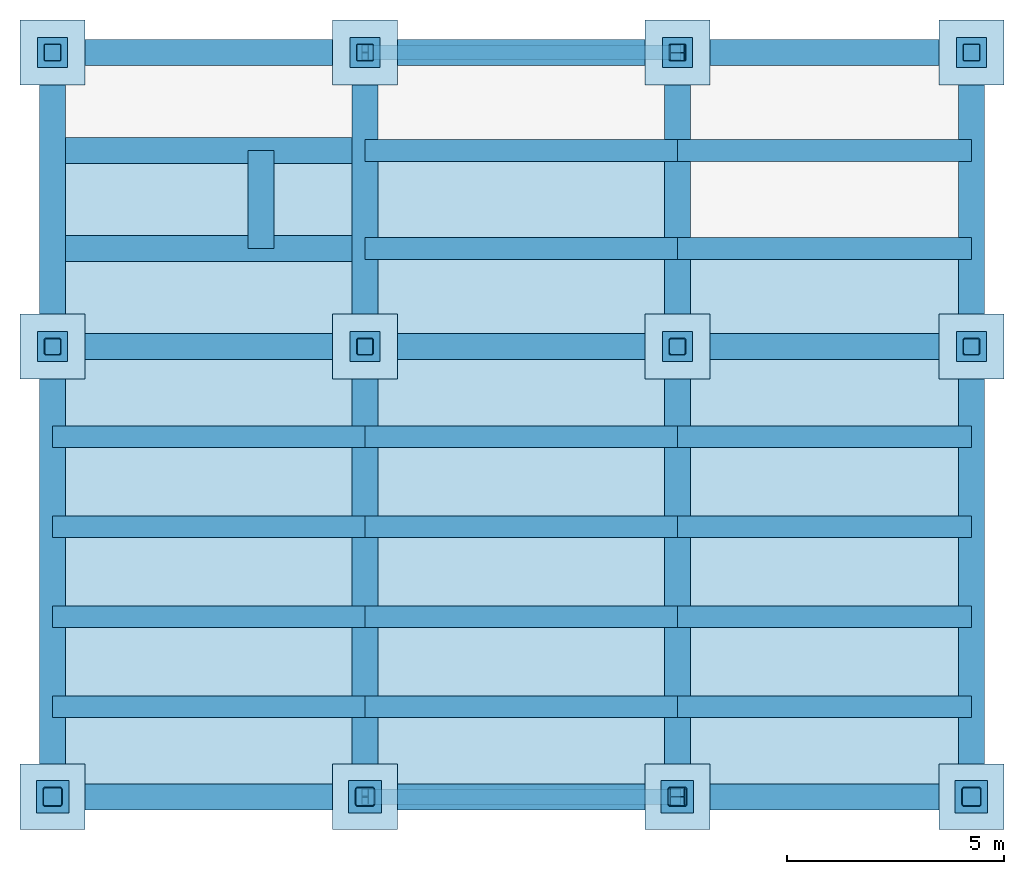
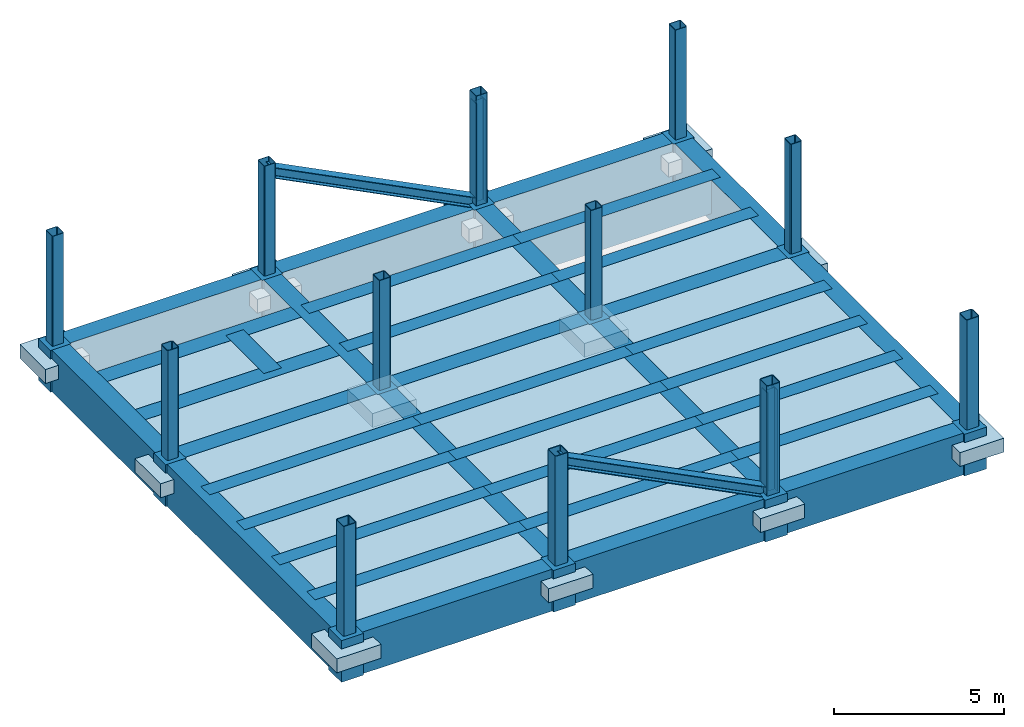
# One storey, part 1 of 2: 36 beams, 26 columns, 21 slabs, 12 footings, 2 members.
"""IFC2X3 building model written with IfcOpenShell, lengths in millimetres."""

from ifc_helpers import new_model, si_unit, frame, origin_with_axes, origin_2d_with_axis, place, context, subcontext, project, spatial, polyline, rectangle, hollow_rectangle, i_section, outline, extrude, material, layer, layer_set, layer_usage, type_object, element, save


model = new_model("IFC2X3")

# Units and contexts
model_context = context("Model", 3, precision=1e-05, world=origin_with_axes())
body_context = subcontext(model_context, "Body", "Model", "MODEL_VIEW")
ifc_project = project(units=[si_unit("LENGTHUNIT", "METRE", prefix="MILLI"), si_unit("AREAUNIT", "SQUARE_METRE"), si_unit("VOLUMEUNIT", "CUBIC_METRE"), si_unit("MASSUNIT", "GRAM", prefix="KILO"), si_unit("TIMEUNIT", "SECOND"), si_unit("PLANEANGLEUNIT", "RADIAN"), si_unit("SOLIDANGLEUNIT", "STERADIAN"), si_unit("THERMODYNAMICTEMPERATUREUNIT", "DEGREE_CELSIUS"), si_unit("LUMINOUSINTENSITYUNIT", "LUMEN")], contexts=[model_context])

# Site, building, storey
site_placement = place(None, origin_with_axes())
site = spatial("IfcSite", under=ifc_project, at=site_placement, CompositionType="ELEMENT")
building_placement = place(site_placement, origin_with_axes())
building = spatial("IfcBuilding", under=site, at=building_placement, Name="Undefined", CompositionType="ELEMENT")
storey_placement = place(building_placement, origin_with_axes())
storey = spatial("IfcBuildingStorey", under=building, at=storey_placement, Name="1", CompositionType="ELEMENT", Elevation=0.0)

# Footings
ifc_material_1 = material(Name="CONCRETE/FC24")
for number, where, z_axis, x_axis, name in (
    (1, (42775.0, 0.0, -600.0), (0.0, 1.0, 0.0), (0.0, 0.0, 1.0), "1FA7"),
    (2, (36000.0, 0.0, -600.0), (0.0, 1.0, 0.0), (0.0, 0.0, 1.0), "1FA6"),
    (3, (28800.0, 0.0, -600.0), (0.0, 1.0, 0.0), (0.0, 0.0, 1.0), "1FA5"),
    (4, (21600.0, 0.0, -600.0), (0.0, 1.0, 0.0), (0.0, 0.0, 1.0), "1FA4"),
    (5, (42775.0, 10375.0, -600.0), (0.0, 1.0, 0.0), (0.0, 0.0, 1.0), "1FB7"),
    (6, (36000.0, 10375.0, -600.0), (0.0, 1.0, 0.0), (0.0, 0.0, 1.0), "1FB6"),
    (7, (28800.0, 10375.0, -600.0), (0.0, 1.0, 0.0), (0.0, 0.0, 1.0), "1FB5"),
    (8, (21600.0, 10375.0, -600.0), (0.0, 1.0, 0.0), (0.0, 0.0, 1.0), "1FB4"),
    (9, (42775.0, 17150.0, -600.0), (0.0, 1.0, 0.0), (0.0, 0.0, 1.0), "1FC7"),
    (10, (36000.0, 17150.0, -600.0), (0.0, 1.0, 0.0), (0.0, 0.0, 1.0), "1FC6"),
    (11, (28800.0, 17150.0, -600.0), (0.0, 1.0, 0.0), (0.0, 0.0, 1.0), "1FC5"),
    (12, (21600.0, 17150.0, -600.0), (0.0, 1.0, 0.0), (0.0, 0.0, 1.0), "1FC4"),
):
    element("IfcFooting", number, at=place(storey_placement, frame(where, z_axis=z_axis, x_axis=x_axis)), inside=storey, material=ifc_material_1, Name=name, PredefinedType="NOTDEFINED", context=body_context, shape_type="SweptSolid", body=[
        extrude(rectangle(XDim=1500.0, YDim=1500.0, at=origin_2d_with_axis()), frame((500.0, 0.0, 0.0), z_axis=(-1.0, 0.0, 0.0), x_axis=(0.0, -1.0, 0.0)), (0.0, 0.0, 1.0), 500.0),
    ])

# Columns
ifc_material_2 = material(Name="STEEL/SN490")
column_type_1 = type_object("IfcColumnType", PredefinedType="NOTDEFINED")
for number, where, z_axis, x_axis, name in (
    (13, (36000.0, 17150.0, 200.0), (0.0, 0.0, 1.0), (-1.0, 0.0, 0.0), "1VC5G2"),
    (14, (36000.0, 0.0, 200.0), (0.0, 0.0, 1.0), (-1.0, 0.0, 0.0), "1VA5G2"),
):
    element("IfcColumn", number, at=place(storey_placement, frame(where, z_axis=z_axis, x_axis=x_axis)), inside=storey, type_object=column_type_1, material=ifc_material_2, Name=name, context=body_context, shape_type="SweptSolid", body=[
        extrude(i_section(OverallWidth=350.0, OverallDepth=350.0, WebThickness=12.0, FlangeThickness=19.0, FilletRadius=13.0, at=origin_2d_with_axis()), frame((0.0, 0.0, 3656.0), z_axis=(0.0, 0.0, -1.0), x_axis=(0.0, 1.0, 0.0)), (0.0, 0.0, 1.0), 3656.0),
    ])
ifc_material_3 = material(Name="STEEL/BCR295")
column_type_2 = type_object("IfcColumnType", PredefinedType="NOTDEFINED")
for number, where, z_axis, x_axis, name in (
    (15, (42775.0, 17150.0, 200.0), (0.0, 0.0, 1.0), (0.0, 1.0, 0.0), "1CC7"),
    (16, (36000.0, 17150.0, 200.0), (0.0, 0.0, 1.0), (0.0, 1.0, 0.0), "1CC6"),
    (17, (28800.0, 17150.0, 200.0), (0.0, 0.0, 1.0), (0.0, 1.0, 0.0), "1CC5"),
    (18, (21600.0, 17150.0, 200.0), (0.0, 0.0, 1.0), (0.0, 1.0, 0.0), "1CC4"),
):
    element("IfcColumn", number, at=place(storey_placement, frame(where, z_axis=z_axis, x_axis=x_axis)), inside=storey, type_object=column_type_2, material=ifc_material_3, Name=name, context=body_context, shape_type="SweptSolid", body=[
        extrude(hollow_rectangle(XDim=400.0, YDim=400.0, WallThickness=16.0, InnerFilletRadius=24.0, OuterFilletRadius=40.0, at=origin_2d_with_axis()), frame((0.0, 0.0, 3950.0), z_axis=(0.0, 0.0, -1.0), x_axis=(0.0, 1.0, 0.0)), (0.0, 0.0, 1.0), 3950.0),
    ])
column_type_3 = type_object("IfcColumnType", PredefinedType="NOTDEFINED")
for number, where, z_axis, x_axis, name in (
    (19, (42775.0, 0.0, 200.0), (0.0, 0.0, 1.0), (0.0, 1.0, 0.0), "1CA7"),
    (20, (36000.0, 0.0, 200.0), (0.0, 0.0, 1.0), (0.0, 1.0, 0.0), "1CA6"),
    (21, (28800.0, 0.0, 200.0), (0.0, 0.0, 1.0), (0.0, 1.0, 0.0), "1CA5"),
    (22, (21600.0, 0.0, 200.0), (0.0, 0.0, 1.0), (0.0, 1.0, 0.0), "1CA4"),
):
    element("IfcColumn", number, at=place(storey_placement, frame(where, z_axis=z_axis, x_axis=x_axis)), inside=storey, type_object=column_type_3, material=ifc_material_3, Name=name, context=body_context, shape_type="SweptSolid", body=[
        extrude(hollow_rectangle(XDim=450.0, YDim=450.0, WallThickness=22.0, InnerFilletRadius=33.0, OuterFilletRadius=55.0, at=origin_2d_with_axis()), frame((0.0, 0.0, 3950.0), z_axis=(0.0, 0.0, -1.0), x_axis=(0.0, 1.0, 0.0)), (0.0, 0.0, 1.0), 3950.0),
    ])
column_type_4 = type_object("IfcColumnType", PredefinedType="NOTDEFINED")
for number, where, z_axis, x_axis, name in (
    (23, (42775.0, 0.0, -1300.0), (0.0, 0.0, 1.0), (0.0, 1.0, 0.0), "1CA7-4"),
    (24, (36000.0, 0.0, -1300.0), (0.0, 0.0, 1.0), (0.0, 1.0, 0.0), "1CA6-4"),
    (25, (28800.0, 0.0, -1300.0), (0.0, 0.0, 1.0), (0.0, 1.0, 0.0), "1CA5-4"),
    (26, (21600.0, 0.0, -1300.0), (0.0, 0.0, 1.0), (0.0, 1.0, 0.0), "1CA4-4"),
):
    element("IfcColumn", number, at=place(storey_placement, frame(where, z_axis=z_axis, x_axis=x_axis)), inside=storey, type_object=column_type_4, material=ifc_material_1, Name=name, context=body_context, shape_type="SweptSolid", body=[
        extrude(rectangle(XDim=750.0, YDim=750.0, at=origin_2d_with_axis()), frame((0.0, 0.0, 1500.0), z_axis=(0.0, 0.0, -1.0), x_axis=(0.0, 1.0, 0.0)), (0.0, 0.0, 1.0), 1500.0),
    ])
column_type_5 = type_object("IfcColumnType", PredefinedType="NOTDEFINED")
for number, where, z_axis, x_axis, name in (
    (27, (42775.0, 10375.0, -1300.0), (0.0, 0.0, 1.0), (0.0, 1.0, 0.0), "1CB7-4"),
    (28, (36000.0, 10375.0, -1300.0), (0.0, 0.0, 1.0), (0.0, 1.0, 0.0), "1CB6-4"),
    (29, (28800.0, 10375.0, -1300.0), (0.0, 0.0, 1.0), (0.0, 1.0, 0.0), "1CB5-4"),
    (30, (21600.0, 10375.0, -1300.0), (0.0, 0.0, 1.0), (0.0, 1.0, 0.0), "1CB4-4"),
    (31, (42775.0, 17150.0, -1300.0), (0.0, 0.0, 1.0), (0.0, 1.0, 0.0), "1CC7-4"),
    (32, (36000.0, 17150.0, -1300.0), (0.0, 0.0, 1.0), (0.0, 1.0, 0.0), "1CC6-4"),
    (33, (28800.0, 17150.0, -1300.0), (0.0, 0.0, 1.0), (0.0, 1.0, 0.0), "1CC5-4"),
    (34, (21600.0, 17150.0, -1300.0), (0.0, 0.0, 1.0), (0.0, 1.0, 0.0), "1CC4-4"),
):
    element("IfcColumn", number, at=place(storey_placement, frame(where, z_axis=z_axis, x_axis=x_axis)), inside=storey, type_object=column_type_5, material=ifc_material_1, Name=name, context=body_context, shape_type="SweptSolid", body=[
        extrude(rectangle(XDim=700.0, YDim=700.0, at=origin_2d_with_axis()), frame((0.0, 0.0, 1500.0), z_axis=(0.0, 0.0, -1.0), x_axis=(0.0, 1.0, 0.0)), (0.0, 0.0, 1.0), 1500.0),
    ])
column_type_6 = type_object("IfcColumnType", PredefinedType="NOTDEFINED")
for number, where, z_axis, x_axis, name in (
    (35, (42775.0, 10375.0, 200.0), (0.0, 0.0, 1.0), (0.0, 1.0, 0.0), "1CB7"),
    (36, (36000.0, 10375.0, 200.0), (0.0, 0.0, 1.0), (0.0, 1.0, 0.0), "1CB6"),
    (37, (28800.0, 10375.0, 200.0), (0.0, 0.0, 1.0), (0.0, 1.0, 0.0), "1CB5"),
    (38, (21600.0, 10375.0, 200.0), (0.0, 0.0, 1.0), (0.0, 1.0, 0.0), "1CB4"),
):
    element("IfcColumn", number, at=place(storey_placement, frame(where, z_axis=z_axis, x_axis=x_axis)), inside=storey, type_object=column_type_6, material=ifc_material_3, Name=name, context=body_context, shape_type="SweptSolid", body=[
        extrude(hollow_rectangle(XDim=400.0, YDim=400.0, WallThickness=22.0, InnerFilletRadius=33.0, OuterFilletRadius=55.0, at=origin_2d_with_axis()), frame((0.0, 0.0, 3950.0), z_axis=(0.0, 0.0, -1.0), x_axis=(0.0, 1.0, 0.0)), (0.0, 0.0, 1.0), 3950.0),
    ])

# Members
member_type = type_object("IfcMemberType", PredefinedType="NOTDEFINED")
for number, where, z_axis, x_axis, name in (
    (39, (36000.0, 17150.0, 200.0), (0.452752949789618, 0.0, 0.891636005585687), (-0.891636005585686, 0.0, 0.452752949789621), "1VC5G1"),
    (40, (36000.0, 0.0, 200.0), (0.452752949789618, 0.0, 0.891636005585687), (-0.891636005585686, 0.0, 0.452752949789621), "1VA5G1"),
):
    element("IfcMember", number, at=place(storey_placement, frame(where, z_axis=z_axis, x_axis=x_axis)), inside=storey, type_object=member_type, material=ifc_material_2, Name=name, context=body_context, shape_type="SweptSolid", body=[
        extrude(i_section(OverallWidth=350.0, OverallDepth=350.0, WebThickness=12.0, FlangeThickness=19.0, FilletRadius=13.0, at=origin_2d_with_axis()), frame((8075.04402473089, 0.0, 4.48254990055901e-13), z_axis=(-1.0, 0.0, 0.0), x_axis=(0.0, -1.0, 0.0)), (0.0, 0.0, 1.0), 8075.04),
    ])

# Beams
beam_type_1 = type_object("IfcBeamType", PredefinedType="NOTDEFINED")
beam_1_placement = place(storey_placement, frame((26400.0, 12633.3, -550.0), z_axis=(0.0, 0.0, 1.0), x_axis=(0.0, 1.0, 0.0)))
element("IfcBeam", 41, at=beam_1_placement, inside=storey, type_object=beam_type_1, material=ifc_material_1, Name="1bB4.3", context=body_context, shape_type="SweptSolid", body=[
    extrude(rectangle(XDim=600.0, YDim=1500.0, at=origin_2d_with_axis()), frame((2258.4, 0.0, 0.0), z_axis=(-1.0, 0.0, 0.0), x_axis=(0.0, -1.0, 0.0)), (0.0, 0.0, 1.0), 2258.4),
])
for number, where, z_axis, x_axis, name in (
    (42, (21600.0, 14891.7, -550.0), (0.0, 0.0, 1.0), (1.0, 0.0, 0.0), "1bB4.2"),
    (43, (21600.0, 12633.3, -550.0), (0.0, 0.0, 1.0), (1.0, 0.0, 0.0), "1bB4.1"),
):
    element("IfcBeam", number, at=place(storey_placement, frame(where, z_axis=z_axis, x_axis=x_axis)), inside=storey, type_object=beam_type_1, material=ifc_material_1, Name=name, context=body_context, shape_type="SweptSolid", body=[
        extrude(rectangle(XDim=600.0, YDim=1500.0, at=origin_2d_with_axis()), frame((7200.0, 0.0, 0.0), z_axis=(-1.0, 0.0, 0.0), x_axis=(0.0, -1.0, 0.0)), (0.0, 0.0, 1.0), 7200.0),
    ])
ifc_material_4 = material(Name="CONCRETE/FC36")
beam_2_placement = place(storey_placement, frame((42775.0, 10375.0, -550.0), z_axis=(0.0, 0.0, 1.0), x_axis=(0.0, 1.0, 0.0)))
element("IfcBeam", 44, at=beam_2_placement, inside=storey, type_object=beam_type_1, material=ifc_material_4, Name="1BB7", context=body_context, shape_type="SweptSolid", body=[
    extrude(rectangle(XDim=600.0, YDim=1500.0, at=origin_2d_with_axis()), frame((6775.0, 0.0, 0.0), z_axis=(-1.0, 0.0, 0.0), x_axis=(0.0, -1.0, 0.0)), (0.0, 0.0, 1.0), 6775.0),
])
beam_3_placement = place(storey_placement, frame((42775.0, 0.0, -550.0), z_axis=(0.0, 0.0, 1.0), x_axis=(0.0, 1.0, 0.0)))
element("IfcBeam", 45, at=beam_3_placement, inside=storey, type_object=beam_type_1, material=ifc_material_4, Name="1BA7", context=body_context, shape_type="SweptSolid", body=[
    extrude(rectangle(XDim=600.0, YDim=1500.0, at=origin_2d_with_axis()), frame((10375.0, 0.0, 0.0), z_axis=(-1.0, 0.0, 0.0), x_axis=(0.0, -1.0, 0.0)), (0.0, 0.0, 1.0), 10375.0),
])
beam_4_placement = place(storey_placement, frame((36000.0, 10375.0, -550.0), z_axis=(0.0, 0.0, 1.0), x_axis=(0.0, 1.0, 0.0)))
element("IfcBeam", 46, at=beam_4_placement, inside=storey, type_object=beam_type_1, material=ifc_material_4, Name="1BB6", context=body_context, shape_type="SweptSolid", body=[
    extrude(rectangle(XDim=600.0, YDim=1500.0, at=origin_2d_with_axis()), frame((6775.0, 0.0, 0.0), z_axis=(-1.0, 0.0, 0.0), x_axis=(0.0, -1.0, 0.0)), (0.0, 0.0, 1.0), 6775.0),
])
beam_5_placement = place(storey_placement, frame((36000.0, 0.0, -550.0), z_axis=(0.0, 0.0, 1.0), x_axis=(0.0, 1.0, 0.0)))
element("IfcBeam", 47, at=beam_5_placement, inside=storey, type_object=beam_type_1, material=ifc_material_4, Name="1BA6", context=body_context, shape_type="SweptSolid", body=[
    extrude(rectangle(XDim=600.0, YDim=1500.0, at=origin_2d_with_axis()), frame((10375.0, 0.0, 0.0), z_axis=(-1.0, 0.0, 0.0), x_axis=(0.0, -1.0, 0.0)), (0.0, 0.0, 1.0), 10375.0),
])
beam_6_placement = place(storey_placement, frame((28800.0, 10375.0, -550.0), z_axis=(0.0, 0.0, 1.0), x_axis=(0.0, 1.0, 0.0)))
element("IfcBeam", 48, at=beam_6_placement, inside=storey, type_object=beam_type_1, material=ifc_material_4, Name="1BB5", context=body_context, shape_type="SweptSolid", body=[
    extrude(rectangle(XDim=600.0, YDim=1500.0, at=origin_2d_with_axis()), frame((6775.0, 0.0, 0.0), z_axis=(-1.0, 0.0, 0.0), x_axis=(0.0, -1.0, 0.0)), (0.0, 0.0, 1.0), 6775.0),
])
beam_7_placement = place(storey_placement, frame((28800.0, 0.0, -550.0), z_axis=(0.0, 0.0, 1.0), x_axis=(0.0, 1.0, 0.0)))
element("IfcBeam", 49, at=beam_7_placement, inside=storey, type_object=beam_type_1, material=ifc_material_4, Name="1BA5", context=body_context, shape_type="SweptSolid", body=[
    extrude(rectangle(XDim=600.0, YDim=1500.0, at=origin_2d_with_axis()), frame((10375.0, 0.0, 0.0), z_axis=(-1.0, 0.0, 0.0), x_axis=(0.0, -1.0, 0.0)), (0.0, 0.0, 1.0), 10375.0),
])
beam_8_placement = place(storey_placement, frame((21600.0, 10375.0, -550.0), z_axis=(0.0, 0.0, 1.0), x_axis=(0.0, 1.0, 0.0)))
element("IfcBeam", 50, at=beam_8_placement, inside=storey, type_object=beam_type_1, material=ifc_material_4, Name="1BB4", context=body_context, shape_type="SweptSolid", body=[
    extrude(rectangle(XDim=600.0, YDim=1500.0, at=origin_2d_with_axis()), frame((6775.0, 0.0, 0.0), z_axis=(-1.0, 0.0, 0.0), x_axis=(0.0, -1.0, 0.0)), (0.0, 0.0, 1.0), 6775.0),
])
beam_9_placement = place(storey_placement, frame((21600.0, 0.0, -550.0), z_axis=(0.0, 0.0, 1.0), x_axis=(0.0, 1.0, 0.0)))
element("IfcBeam", 51, at=beam_9_placement, inside=storey, type_object=beam_type_1, material=ifc_material_4, Name="1BA4", context=body_context, shape_type="SweptSolid", body=[
    extrude(rectangle(XDim=600.0, YDim=1500.0, at=origin_2d_with_axis()), frame((10375.0, 0.0, 0.0), z_axis=(-1.0, 0.0, 0.0), x_axis=(0.0, -1.0, 0.0)), (0.0, 0.0, 1.0), 10375.0),
])
beam_10_placement = place(storey_placement, frame((36000.0, 0.0, -550.0), z_axis=(0.0, 0.0, 1.0), x_axis=(1.0, 0.0, 0.0)))
element("IfcBeam", 52, at=beam_10_placement, inside=storey, type_object=beam_type_1, material=ifc_material_4, Name="1GA6", context=body_context, shape_type="SweptSolid", body=[
    extrude(rectangle(XDim=600.0, YDim=1500.0, at=origin_2d_with_axis()), frame((6775.0, 0.0, 0.0), z_axis=(-1.0, 0.0, 0.0), x_axis=(0.0, -1.0, 0.0)), (0.0, 0.0, 1.0), 6775.0),
])
for number, where, z_axis, x_axis, name in (
    (53, (28800.0, 0.0, -550.0), (0.0, 0.0, 1.0), (1.0, 0.0, 0.0), "1GA5"),
    (54, (21600.0, 0.0, -550.0), (0.0, 0.0, 1.0), (1.0, 0.0, 0.0), "1GA4"),
):
    element("IfcBeam", number, at=place(storey_placement, frame(where, z_axis=z_axis, x_axis=x_axis)), inside=storey, type_object=beam_type_1, material=ifc_material_4, Name=name, context=body_context, shape_type="SweptSolid", body=[
        extrude(rectangle(XDim=600.0, YDim=1500.0, at=origin_2d_with_axis()), frame((7200.0, 0.0, 0.0), z_axis=(-1.0, 0.0, 0.0), x_axis=(0.0, -1.0, 0.0)), (0.0, 0.0, 1.0), 7200.0),
    ])
beam_11_placement = place(storey_placement, frame((36000.0, 10375.0, -550.0), z_axis=(0.0, 0.0, 1.0), x_axis=(1.0, 0.0, 0.0)))
element("IfcBeam", 55, at=beam_11_placement, inside=storey, type_object=beam_type_1, material=ifc_material_4, Name="1GB6", context=body_context, shape_type="SweptSolid", body=[
    extrude(rectangle(XDim=600.0, YDim=1500.0, at=origin_2d_with_axis()), frame((6775.0, 0.0, 0.0), z_axis=(-1.0, 0.0, 0.0), x_axis=(0.0, -1.0, 0.0)), (0.0, 0.0, 1.0), 6775.0),
])
for number, where, z_axis, x_axis, name in (
    (56, (28800.0, 10375.0, -550.0), (0.0, 0.0, 1.0), (1.0, 0.0, 0.0), "1GB5"),
    (57, (21600.0, 10375.0, -550.0), (0.0, 0.0, 1.0), (1.0, 0.0, 0.0), "1GB4"),
):
    element("IfcBeam", number, at=place(storey_placement, frame(where, z_axis=z_axis, x_axis=x_axis)), inside=storey, type_object=beam_type_1, material=ifc_material_4, Name=name, context=body_context, shape_type="SweptSolid", body=[
        extrude(rectangle(XDim=600.0, YDim=1500.0, at=origin_2d_with_axis()), frame((7200.0, 0.0, 0.0), z_axis=(-1.0, 0.0, 0.0), x_axis=(0.0, -1.0, 0.0)), (0.0, 0.0, 1.0), 7200.0),
    ])
beam_12_placement = place(storey_placement, frame((36000.0, 17150.0, -550.0), z_axis=(0.0, 0.0, 1.0), x_axis=(1.0, 0.0, 0.0)))
element("IfcBeam", 58, at=beam_12_placement, inside=storey, type_object=beam_type_1, material=ifc_material_4, Name="1GC6", context=body_context, shape_type="SweptSolid", body=[
    extrude(rectangle(XDim=600.0, YDim=1500.0, at=origin_2d_with_axis()), frame((6775.0, 0.0, 0.0), z_axis=(-1.0, 0.0, 0.0), x_axis=(0.0, -1.0, 0.0)), (0.0, 0.0, 1.0), 6775.0),
])
for number, where, z_axis, x_axis, name in (
    (59, (28800.0, 17150.0, -550.0), (0.0, 0.0, 1.0), (1.0, 0.0, 0.0), "1GC5"),
    (60, (21600.0, 17150.0, -550.0), (0.0, 0.0, 1.0), (1.0, 0.0, 0.0), "1GC4"),
):
    element("IfcBeam", number, at=place(storey_placement, frame(where, z_axis=z_axis, x_axis=x_axis)), inside=storey, type_object=beam_type_1, material=ifc_material_4, Name=name, context=body_context, shape_type="SweptSolid", body=[
        extrude(rectangle(XDim=600.0, YDim=1500.0, at=origin_2d_with_axis()), frame((7200.0, 0.0, 0.0), z_axis=(-1.0, 0.0, 0.0), x_axis=(0.0, -1.0, 0.0)), (0.0, 0.0, 1.0), 7200.0),
    ])
beam_type_2 = type_object("IfcBeamType", PredefinedType="NOTDEFINED")
for number, where, z_axis, x_axis, name in (
    (61, (36000.0, 8300.0, -400.0), (0.0, 0.0, 1.0), (1.0, 0.0, 0.0), "1bA6.4"),
    (62, (36000.0, 6225.0, -400.0), (0.0, 0.0, 1.0), (1.0, 0.0, 0.0), "1bA6.3"),
    (63, (36000.0, 4150.0, -400.0), (0.0, 0.0, 1.0), (1.0, 0.0, 0.0), "1bA6.2"),
    (64, (36000.0, 2075.0, -400.0), (0.0, 0.0, 1.0), (1.0, 0.0, 0.0), "1bA6.1"),
):
    element("IfcBeam", number, at=place(storey_placement, frame(where, z_axis=z_axis, x_axis=x_axis)), inside=storey, type_object=beam_type_2, material=ifc_material_1, Name=name, context=body_context, shape_type="SweptSolid", body=[
        extrude(rectangle(XDim=500.0, YDim=1200.0, at=origin_2d_with_axis()), frame((6775.0, 0.0, 0.0), z_axis=(-1.0, 0.0, 0.0), x_axis=(0.0, -1.0, 0.0)), (0.0, 0.0, 1.0), 6775.0),
    ])
for number, where, z_axis, x_axis, name in (
    (65, (28800.0, 8300.0, -400.0), (0.0, 0.0, 1.0), (1.0, 0.0, 0.0), "1bA5.4"),
    (66, (28800.0, 6225.0, -400.0), (0.0, 0.0, 1.0), (1.0, 0.0, 0.0), "1bA5.3"),
    (67, (28800.0, 4150.0, -400.0), (0.0, 0.0, 1.0), (1.0, 0.0, 0.0), "1bA5.2"),
    (68, (28800.0, 2075.0, -400.0), (0.0, 0.0, 1.0), (1.0, 0.0, 0.0), "1bA5.1"),
    (69, (21600.0, 8300.0, -400.0), (0.0, 0.0, 1.0), (1.0, 0.0, 0.0), "1bA4.4"),
    (70, (21600.0, 6225.0, -400.0), (0.0, 0.0, 1.0), (1.0, 0.0, 0.0), "1bA4.3"),
    (71, (21600.0, 4150.0, -400.0), (0.0, 0.0, 1.0), (1.0, 0.0, 0.0), "1bA4.2"),
    (72, (21600.0, 2075.0, -400.0), (0.0, 0.0, 1.0), (1.0, 0.0, 0.0), "1bA4.1"),
):
    element("IfcBeam", number, at=place(storey_placement, frame(where, z_axis=z_axis, x_axis=x_axis)), inside=storey, type_object=beam_type_2, material=ifc_material_1, Name=name, context=body_context, shape_type="SweptSolid", body=[
        extrude(rectangle(XDim=500.0, YDim=1200.0, at=origin_2d_with_axis()), frame((7200.0, 0.0, 0.0), z_axis=(-1.0, 0.0, 0.0), x_axis=(0.0, -1.0, 0.0)), (0.0, 0.0, 1.0), 7200.0),
    ])
for number, where, z_axis, x_axis, name in (
    (73, (36000.0, 14891.7, -400.0), (0.0, 0.0, 1.0), (1.0, 0.0, 0.0), "1bB6.2"),
    (74, (36000.0, 12633.3, -400.0), (0.0, 0.0, 1.0), (1.0, 0.0, 0.0), "1bB6.1"),
):
    element("IfcBeam", number, at=place(storey_placement, frame(where, z_axis=z_axis, x_axis=x_axis)), inside=storey, type_object=beam_type_2, material=ifc_material_1, Name=name, context=body_context, shape_type="SweptSolid", body=[
        extrude(rectangle(XDim=500.0, YDim=1200.0, at=origin_2d_with_axis()), frame((6775.0, 0.0, 0.0), z_axis=(-1.0, 0.0, 0.0), x_axis=(0.0, -1.0, 0.0)), (0.0, 0.0, 1.0), 6775.0),
    ])
for number, where, z_axis, x_axis, name in (
    (75, (28800.0, 14891.7, -400.0), (0.0, 0.0, 1.0), (1.0, 0.0, 0.0), "1bB5.2"),
    (76, (28800.0, 12633.3, -400.0), (0.0, 0.0, 1.0), (1.0, 0.0, 0.0), "1bB5.1"),
):
    element("IfcBeam", number, at=place(storey_placement, frame(where, z_axis=z_axis, x_axis=x_axis)), inside=storey, type_object=beam_type_2, material=ifc_material_1, Name=name, context=body_context, shape_type="SweptSolid", body=[
        extrude(rectangle(XDim=500.0, YDim=1200.0, at=origin_2d_with_axis()), frame((7200.0, 0.0, 0.0), z_axis=(-1.0, 0.0, 0.0), x_axis=(0.0, -1.0, 0.0)), (0.0, 0.0, 1.0), 7200.0),
    ])

# Slabs
ifc_layer_1 = layer(ifc_material_1, 200.0)
ifc_layer_set_1 = layer_set([ifc_layer_1], Name="Floor: Insitu CONCRETE/FC24")
ifc_layer_usage_1 = layer_usage(ifc_layer_set_1, "AXIS3", "POSITIVE", -100.0)
slab_type_1 = type_object("IfcSlabType", PredefinedType="NOTDEFINED")
slab_1_placement = place(storey_placement, frame((36000.0, 0.0, 100.0), z_axis=(0.0, 0.0, 1.0), x_axis=(1.0, 0.0, 0.0)))
element("IfcSlab", 77, at=slab_1_placement, inside=storey, type_object=slab_type_1, material=ifc_layer_usage_1, Name="1SA6.1", PredefinedType="FLOOR", context=body_context, shape_type="SweptSolid", body=[
    extrude(outline(polyline([(0.0, 0.0), (6775.0, 0.0), (6775.0, 2075.0), (0.0, 2075.0), (0.0, 0.0)])), frame((0.0, 0.0, -100.0), z_axis=(0.0, 0.0, 1.0), x_axis=(1.0, 0.0, 0.0)), (0.0, 0.0, 1.0), 200.0),
])
ifc_layer_usage_2 = layer_usage(ifc_layer_set_1, "AXIS3", "POSITIVE", -100.0)
slab_2_placement = place(storey_placement, frame((28800.0, 0.0, 100.0), z_axis=(0.0, 0.0, 1.0), x_axis=(1.0, 0.0, 0.0)))
element("IfcSlab", 78, at=slab_2_placement, inside=storey, type_object=slab_type_1, material=ifc_layer_usage_2, Name="1SA5.1", PredefinedType="FLOOR", context=body_context, shape_type="SweptSolid", body=[
    extrude(outline(polyline([(0.0, 0.0), (7200.0, 0.0), (7200.0, 2075.0), (0.0, 2075.0), (0.0, 0.0)])), frame((0.0, 0.0, -100.0), z_axis=(0.0, 0.0, 1.0), x_axis=(1.0, 0.0, 0.0)), (0.0, 0.0, 1.0), 200.0),
])
ifc_layer_usage_3 = layer_usage(ifc_layer_set_1, "AXIS3", "POSITIVE", -100.0)
slab_3_placement = place(storey_placement, frame((21600.0, 0.0, 100.0), z_axis=(0.0, 0.0, 1.0), x_axis=(1.0, 0.0, 0.0)))
element("IfcSlab", 79, at=slab_3_placement, inside=storey, type_object=slab_type_1, material=ifc_layer_usage_3, Name="1SA4.1", PredefinedType="FLOOR", context=body_context, shape_type="SweptSolid", body=[
    extrude(outline(polyline([(0.0, 0.0), (7200.0, 0.0), (7200.0, 2075.0), (0.0, 2075.0), (0.0, 0.0)])), frame((0.0, 0.0, -100.0), z_axis=(0.0, 0.0, 1.0), x_axis=(1.0, 0.0, 0.0)), (0.0, 0.0, 1.0), 200.0),
])
ifc_layer_usage_4 = layer_usage(ifc_layer_set_1, "AXIS3", "POSITIVE", -100.0)
slab_4_placement = place(storey_placement, frame((21600.0, 2075.0, 100.0), z_axis=(0.0, 0.0, 1.0), x_axis=(1.0, 0.0, 0.0)))
element("IfcSlab", 80, at=slab_4_placement, inside=storey, type_object=slab_type_1, material=ifc_layer_usage_4, Name="1SA4.2", PredefinedType="FLOOR", context=body_context, shape_type="SweptSolid", body=[
    extrude(outline(polyline([(0.0, 0.0), (7200.0, 0.0), (7200.0, 1100.0), (7200.0, 2075.0), (0.0, 2075.0), (0.0, 1100.0), (0.0, 0.0)])), frame((0.0, 0.0, -100.0), z_axis=(0.0, 0.0, 1.0), x_axis=(1.0, 0.0, 0.0)), (0.0, 0.0, 1.0), 200.0),
])
ifc_layer_usage_5 = layer_usage(ifc_layer_set_1, "AXIS3", "POSITIVE", -100.0)
slab_5_placement = place(storey_placement, frame((28800.0, 2075.0, 100.0), z_axis=(0.0, 0.0, 1.0), x_axis=(1.0, 0.0, 0.0)))
element("IfcSlab", 81, at=slab_5_placement, inside=storey, type_object=slab_type_1, material=ifc_layer_usage_5, Name="1SA5.2", PredefinedType="FLOOR", context=body_context, shape_type="SweptSolid", body=[
    extrude(outline(polyline([(0.0, 0.0), (7200.0, 0.0), (7200.0, 1100.0), (7200.0, 2075.0), (0.0, 2075.0), (0.0, 1100.0), (0.0, 0.0)])), frame((0.0, 0.0, -100.0), z_axis=(0.0, 0.0, 1.0), x_axis=(1.0, 0.0, 0.0)), (0.0, 0.0, 1.0), 200.0),
])
ifc_layer_usage_6 = layer_usage(ifc_layer_set_1, "AXIS3", "POSITIVE", -100.0)
slab_6_placement = place(storey_placement, frame((36000.0, 4150.0, 100.0), z_axis=(0.0, 0.0, 1.0), x_axis=(1.0, 0.0, 0.0)))
element("IfcSlab", 82, at=slab_6_placement, inside=storey, type_object=slab_type_1, material=ifc_layer_usage_6, Name="1SA6.3", PredefinedType="FLOOR", context=body_context, shape_type="SweptSolid", body=[
    extrude(outline(polyline([(0.0, 0.0), (6775.0, 0.0), (6775.0, 2075.0), (0.0, 2075.0), (0.0, 0.0)])), frame((0.0, 0.0, -100.0), z_axis=(0.0, 0.0, 1.0), x_axis=(1.0, 0.0, 0.0)), (0.0, 0.0, 1.0), 200.0),
])
ifc_layer_usage_7 = layer_usage(ifc_layer_set_1, "AXIS3", "POSITIVE", -100.0)
slab_7_placement = place(storey_placement, frame((36000.0, 2075.0, 100.0), z_axis=(0.0, 0.0, 1.0), x_axis=(1.0, 0.0, 0.0)))
element("IfcSlab", 83, at=slab_7_placement, inside=storey, type_object=slab_type_1, material=ifc_layer_usage_7, Name="1SA6.2", PredefinedType="FLOOR", context=body_context, shape_type="SweptSolid", body=[
    extrude(outline(polyline([(0.0, 0.0), (6775.0, 0.0), (6775.0, 1100.0), (6775.0, 2075.0), (0.0, 2075.0), (0.0, 1100.0), (0.0, 0.0)])), frame((0.0, 0.0, -100.0), z_axis=(0.0, 0.0, 1.0), x_axis=(1.0, 0.0, 0.0)), (0.0, 0.0, 1.0), 200.0),
])
ifc_layer_usage_8 = layer_usage(ifc_layer_set_1, "AXIS3", "POSITIVE", -100.0)
slab_8_placement = place(storey_placement, frame((28800.0, 4150.0, 100.0), z_axis=(0.0, 0.0, 1.0), x_axis=(1.0, 0.0, 0.0)))
element("IfcSlab", 84, at=slab_8_placement, inside=storey, type_object=slab_type_1, material=ifc_layer_usage_8, Name="1SA5.3", PredefinedType="FLOOR", context=body_context, shape_type="SweptSolid", body=[
    extrude(outline(polyline([(0.0, 0.0), (7200.0, 0.0), (7200.0, 2075.0), (0.0, 2075.0), (0.0, 0.0)])), frame((0.0, 0.0, -100.0), z_axis=(0.0, 0.0, 1.0), x_axis=(1.0, 0.0, 0.0)), (0.0, 0.0, 1.0), 200.0),
])
ifc_layer_usage_9 = layer_usage(ifc_layer_set_1, "AXIS3", "POSITIVE", -100.0)
slab_9_placement = place(storey_placement, frame((21600.0, 4150.0, 100.0), z_axis=(0.0, 0.0, 1.0), x_axis=(1.0, 0.0, 0.0)))
element("IfcSlab", 85, at=slab_9_placement, inside=storey, type_object=slab_type_1, material=ifc_layer_usage_9, Name="1SA4.3", PredefinedType="FLOOR", context=body_context, shape_type="SweptSolid", body=[
    extrude(outline(polyline([(0.0, 0.0), (7200.0, 0.0), (7200.0, 2075.0), (0.0, 2075.0), (0.0, 0.0)])), frame((0.0, 0.0, -100.0), z_axis=(0.0, 0.0, 1.0), x_axis=(1.0, 0.0, 0.0)), (0.0, 0.0, 1.0), 200.0),
])
ifc_layer_usage_10 = layer_usage(ifc_layer_set_1, "AXIS3", "POSITIVE", -100.0)
slab_10_placement = place(storey_placement, frame((21600.0, 6225.0, 100.0), z_axis=(0.0, 0.0, 1.0), x_axis=(1.0, 0.0, 0.0)))
element("IfcSlab", 86, at=slab_10_placement, inside=storey, type_object=slab_type_1, material=ifc_layer_usage_10, Name="1SA4.4", PredefinedType="FLOOR", context=body_context, shape_type="SweptSolid", body=[
    extrude(outline(polyline([(0.0, 0.0), (7200.0, 0.0), (7200.0, 550.0), (7200.0, 2075.0), (0.0, 2075.0), (0.0, 550.0), (0.0, 0.0)])), frame((0.0, 0.0, -100.0), z_axis=(0.0, 0.0, 1.0), x_axis=(1.0, 0.0, 0.0)), (0.0, 0.0, 1.0), 200.0),
])
ifc_layer_usage_11 = layer_usage(ifc_layer_set_1, "AXIS3", "POSITIVE", -100.0)
slab_11_placement = place(storey_placement, frame((28800.0, 6225.0, 100.0), z_axis=(0.0, 0.0, 1.0), x_axis=(1.0, 0.0, 0.0)))
element("IfcSlab", 87, at=slab_11_placement, inside=storey, type_object=slab_type_1, material=ifc_layer_usage_11, Name="1SA5.4", PredefinedType="FLOOR", context=body_context, shape_type="SweptSolid", body=[
    extrude(outline(polyline([(0.0, 0.0), (7200.0, 0.0), (7200.0, 550.0), (7200.0, 2075.0), (0.0, 2075.0), (0.0, 550.0), (0.0, 0.0)])), frame((0.0, 0.0, -100.0), z_axis=(0.0, 0.0, 1.0), x_axis=(1.0, 0.0, 0.0)), (0.0, 0.0, 1.0), 200.0),
])
ifc_layer_usage_12 = layer_usage(ifc_layer_set_1, "AXIS3", "POSITIVE", -100.0)
slab_12_placement = place(storey_placement, frame((36000.0, 6225.0, 100.0), z_axis=(0.0, 0.0, 1.0), x_axis=(1.0, 0.0, 0.0)))
element("IfcSlab", 88, at=slab_12_placement, inside=storey, type_object=slab_type_1, material=ifc_layer_usage_12, Name="1SA6.4", PredefinedType="FLOOR", context=body_context, shape_type="SweptSolid", body=[
    extrude(outline(polyline([(0.0, 0.0), (6775.0, 0.0), (6775.0, 550.0), (6775.0, 2075.0), (0.0, 2075.0), (0.0, 550.0), (0.0, 0.0)])), frame((0.0, 0.0, -100.0), z_axis=(0.0, 0.0, 1.0), x_axis=(1.0, 0.0, 0.0)), (0.0, 0.0, 1.0), 200.0),
])
ifc_layer_usage_13 = layer_usage(ifc_layer_set_1, "AXIS3", "POSITIVE", -100.0)
slab_13_placement = place(storey_placement, frame((36000.0, 8300.0, 100.0), z_axis=(0.0, 0.0, 1.0), x_axis=(1.0, 0.0, 0.0)))
element("IfcSlab", 89, at=slab_13_placement, inside=storey, type_object=slab_type_1, material=ifc_layer_usage_13, Name="1SA6.5", PredefinedType="FLOOR", context=body_context, shape_type="SweptSolid", body=[
    extrude(outline(polyline([(0.0, 0.0), (6775.0, 0.0), (6775.0, 2075.0), (0.0, 2075.0), (0.0, 0.0)])), frame((0.0, 0.0, -100.0), z_axis=(0.0, 0.0, 1.0), x_axis=(1.0, 0.0, 0.0)), (0.0, 0.0, 1.0), 200.0),
])
ifc_layer_usage_14 = layer_usage(ifc_layer_set_1, "AXIS3", "POSITIVE", -100.0)
slab_14_placement = place(storey_placement, frame((28800.0, 8300.0, 100.0), z_axis=(0.0, 0.0, 1.0), x_axis=(1.0, 0.0, 0.0)))
element("IfcSlab", 90, at=slab_14_placement, inside=storey, type_object=slab_type_1, material=ifc_layer_usage_14, Name="1SA5.5", PredefinedType="FLOOR", context=body_context, shape_type="SweptSolid", body=[
    extrude(outline(polyline([(0.0, 0.0), (7200.0, 0.0), (7200.0, 2075.0), (0.0, 2075.0), (0.0, 0.0)])), frame((0.0, 0.0, -100.0), z_axis=(0.0, 0.0, 1.0), x_axis=(1.0, 0.0, 0.0)), (0.0, 0.0, 1.0), 200.0),
])
ifc_layer_usage_15 = layer_usage(ifc_layer_set_1, "AXIS3", "POSITIVE", -100.0)
slab_15_placement = place(storey_placement, frame((21600.0, 8300.0, 100.0), z_axis=(0.0, 0.0, 1.0), x_axis=(1.0, 0.0, 0.0)))
element("IfcSlab", 91, at=slab_15_placement, inside=storey, type_object=slab_type_1, material=ifc_layer_usage_15, Name="1SA4.5", PredefinedType="FLOOR", context=body_context, shape_type="SweptSolid", body=[
    extrude(outline(polyline([(0.0, 0.0), (7200.0, 0.0), (7200.0, 2075.0), (0.0, 2075.0), (0.0, 0.0)])), frame((0.0, 0.0, -100.0), z_axis=(0.0, 0.0, 1.0), x_axis=(1.0, 0.0, 0.0)), (0.0, 0.0, 1.0), 200.0),
])
ifc_layer_usage_16 = layer_usage(ifc_layer_set_1, "AXIS3", "POSITIVE", -100.0)
slab_type_2 = type_object("IfcSlabType", PredefinedType="NOTDEFINED")
slab_16_placement = place(storey_placement, frame((36000.0, 10375.0, 100.0), z_axis=(0.0, 0.0, 1.0), x_axis=(1.0, 0.0, 0.0)))
element("IfcSlab", 92, at=slab_16_placement, inside=storey, type_object=slab_type_2, material=ifc_layer_usage_16, Name="1SB6.1", PredefinedType="FLOOR", context=body_context, shape_type="SweptSolid", body=[
    extrude(outline(polyline([(0.0, 0.0), (6775.0, 0.0), (6775.0, 2258.30004882813), (0.0, 2258.30004882813), (0.0, 0.0)])), frame((0.0, 0.0, -100.0), z_axis=(0.0, 0.0, 1.0), x_axis=(1.0, 0.0, 0.0)), (0.0, 0.0, 1.0), 200.0),
])
ifc_layer_usage_17 = layer_usage(ifc_layer_set_1, "AXIS3", "POSITIVE", -100.0)
slab_17_placement = place(storey_placement, frame((28800.0, 12633.3, 100.0), z_axis=(0.0, 0.0, 1.0), x_axis=(1.0, 0.0, 0.0)))
element("IfcSlab", 93, at=slab_17_placement, inside=storey, type_object=slab_type_2, material=ifc_layer_usage_17, Name="1SB5.2", PredefinedType="FLOOR", context=body_context, shape_type="SweptSolid", body=[
    extrude(outline(polyline([(0.0, 0.0), (7200.0, 0.0), (7200.0, 1341.69995117188), (7200.0, 2258.39990234375), (0.0, 2258.39990234375), (0.0, 1341.69995117188), (0.0, 0.0)])), frame((0.0, 0.0, -100.0), z_axis=(0.0, 0.0, 1.0), x_axis=(1.0, 0.0, 0.0)), (0.0, 0.0, 1.0), 200.0),
])
ifc_layer_usage_18 = layer_usage(ifc_layer_set_1, "AXIS3", "POSITIVE", -100.0)
slab_18_placement = place(storey_placement, frame((28800.0, 10375.0, 100.0), z_axis=(0.0, 0.0, 1.0), x_axis=(1.0, 0.0, 0.0)))
element("IfcSlab", 94, at=slab_18_placement, inside=storey, type_object=slab_type_2, material=ifc_layer_usage_18, Name="1SB5.1", PredefinedType="FLOOR", context=body_context, shape_type="SweptSolid", body=[
    extrude(outline(polyline([(0.0, 0.0), (7200.0, 0.0), (7200.0, 2258.30004882813), (0.0, 2258.30004882813), (0.0, 0.0)])), frame((0.0, 0.0, -100.0), z_axis=(0.0, 0.0, 1.0), x_axis=(1.0, 0.0, 0.0)), (0.0, 0.0, 1.0), 200.0),
])
ifc_layer_usage_19 = layer_usage(ifc_layer_set_1, "AXIS3", "POSITIVE", -100.0)
slab_19_placement = place(storey_placement, frame((21600.0, 10375.0, 100.0), z_axis=(0.0, 0.0, 1.0), x_axis=(1.0, 0.0, 0.0)))
element("IfcSlab", 95, at=slab_19_placement, inside=storey, type_object=slab_type_2, material=ifc_layer_usage_19, Name="1SB4.1", PredefinedType="FLOOR", context=body_context, shape_type="SweptSolid", body=[
    extrude(outline(polyline([(0.0, 0.0), (7200.0, 0.0), (7200.0, 2258.30004882813), (0.0, 2258.30004882813), (0.0, 0.0)])), frame((0.0, 0.0, -100.0), z_axis=(0.0, 0.0, 1.0), x_axis=(1.0, 0.0, 0.0)), (0.0, 0.0, 1.0), 200.0),
])
ifc_layer_usage_20 = layer_usage(ifc_layer_set_1, "AXIS3", "POSITIVE", -100.0)
slab_20_placement = place(storey_placement, frame((21600.0, 12633.3, 100.0), z_axis=(0.0, 0.0, 1.0), x_axis=(1.0, 0.0, 0.0)))
element("IfcSlab", 96, at=slab_20_placement, inside=storey, type_object=slab_type_2, material=ifc_layer_usage_20, Name="1SB4.2", PredefinedType="FLOOR", context=body_context, shape_type="SweptSolid", body=[
    extrude(outline(polyline([(0.0, 0.0), (4800.0, 0.0), (4800.0, 2258.39990234375), (0.0, 2258.39990234375), (0.0, 1341.69995117188), (0.0, 0.0)])), frame((0.0, 0.0, -100.0), z_axis=(0.0, 0.0, 1.0), x_axis=(1.0, 0.0, 0.0)), (0.0, 0.0, 1.0), 200.0),
])
ifc_layer_2 = layer(ifc_material_4, 300.0)
ifc_layer_set_2 = layer_set([ifc_layer_2], Name="Floor: Insitu CONCRETE/FC36")
ifc_layer_usage_21 = layer_usage(ifc_layer_set_2, "AXIS3", "POSITIVE", -150.0)
slab_type_3 = type_object("IfcSlabType", PredefinedType="NOTDEFINED")
slab_21_placement = place(storey_placement, frame((26400.0, 12633.3, 50.0), z_axis=(0.0, 0.0, 1.0), x_axis=(1.0, 0.0, 0.0)))
element("IfcSlab", 97, at=slab_21_placement, inside=storey, type_object=slab_type_3, material=ifc_layer_usage_21, Name="1SB4.4L", PredefinedType="FLOOR", context=body_context, shape_type="SweptSolid", body=[
    extrude(outline(polyline([(0.0, 0.0), (2400.0, 0.0), (2400.0, 1341.69995117188), (2400.0, 2258.39990234375), (0.0, 2258.39990234375), (0.0, 0.0)])), frame((0.0, 0.0, -150.0), z_axis=(0.0, 0.0, 1.0), x_axis=(1.0, 0.0, 0.0)), (0.0, 0.0, 1.0), 300.0),
])

save(model, "model.ifc")
